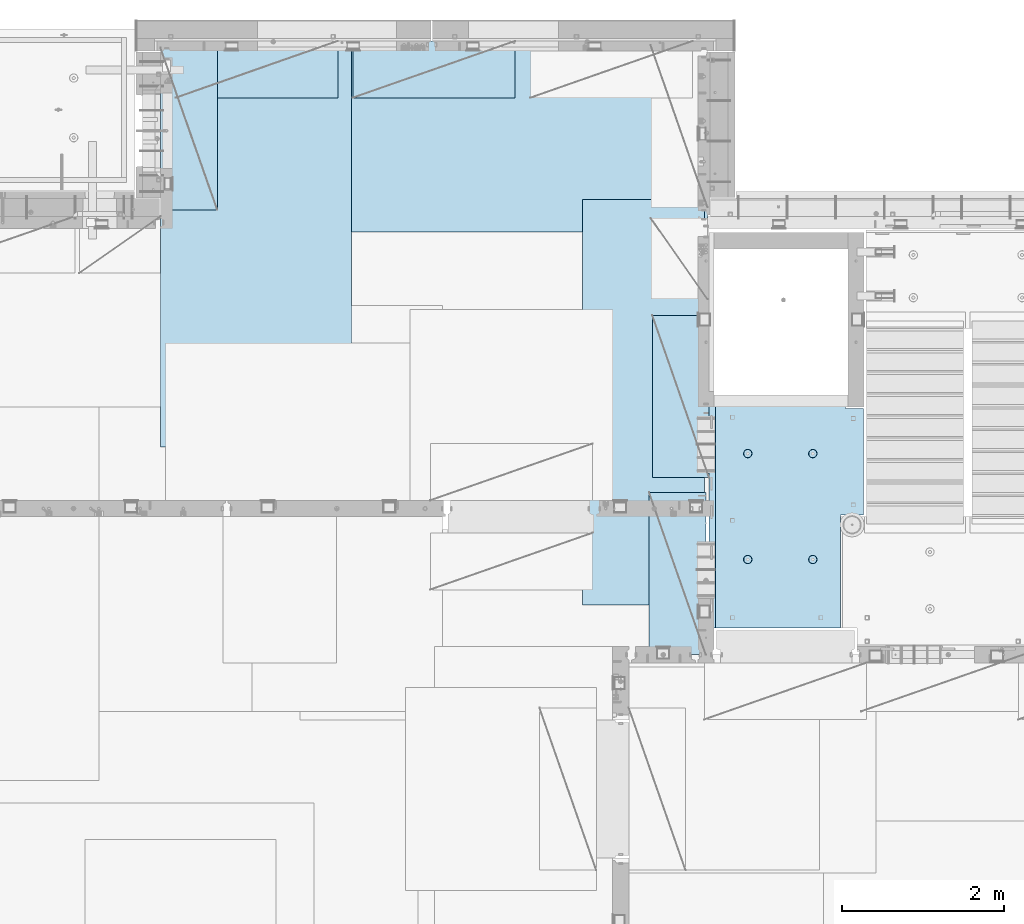
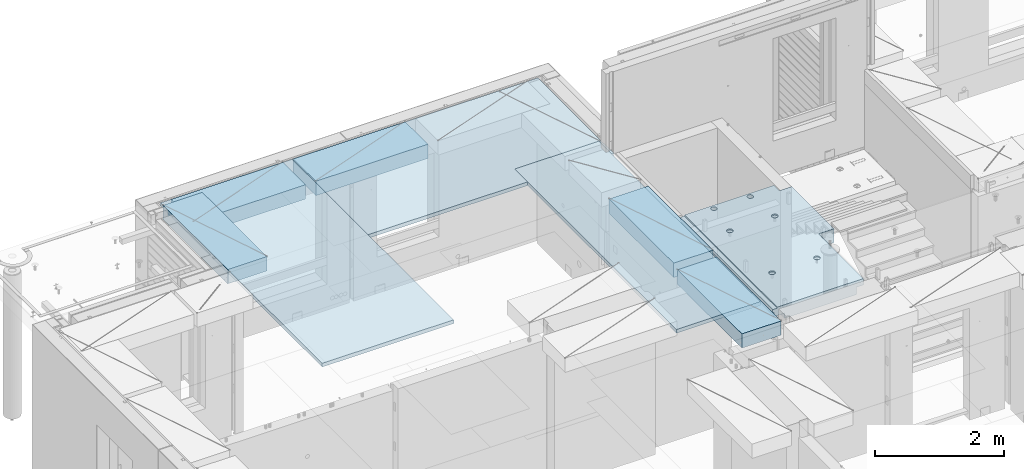
# One storey, part 206 of 349: 8 plates, 1 slab, 9 elements without a shape of their own.
"""IFC2X3 building model written with IfcOpenShell, lengths in millimetres."""

from ifc_helpers import new_model, si_unit, frame, origin_with_axes, place, context, subcontext, project, spatial, faceted_brep, material, type_object, element, aggregate, save


model = new_model("IFC2X3")

# Units and contexts
model_context = context("Model", 3, precision=1e-05, world=origin_with_axes())
body_context = subcontext(model_context, "Body", "Model", "MODEL_VIEW")
ifc_project = project(units=[si_unit("LENGTHUNIT", "METRE", prefix="MILLI"), si_unit("AREAUNIT", "SQUARE_METRE"), si_unit("VOLUMEUNIT", "CUBIC_METRE"), si_unit("MASSUNIT", "GRAM", prefix="KILO"), si_unit("TIMEUNIT", "SECOND"), si_unit("PLANEANGLEUNIT", "RADIAN"), si_unit("SOLIDANGLEUNIT", "STERADIAN"), si_unit("THERMODYNAMICTEMPERATUREUNIT", "DEGREE_CELSIUS"), si_unit("LUMINOUSINTENSITYUNIT", "LUMEN")], contexts=[model_context])

# Site, building, storey
site_placement = place(None, origin_with_axes())
site = spatial("IfcSite", under=ifc_project, at=site_placement, CompositionType="ELEMENT")
building_placement = place(site_placement, origin_with_axes())
building = spatial("IfcBuilding", under=site, at=building_placement, CompositionType="ELEMENT")
storey_placement = place(building_placement, origin_with_axes())
storey = spatial("IfcBuildingStorey", under=building, at=storey_placement, Name="4", CompositionType="ELEMENT", Elevation=0.0)

# Assembly, slab
assembly_1_placement = place(storey_placement, origin_with_axes())
assembly_1 = element("IfcElementAssembly", 1, at=assembly_1_placement, inside=storey, AssemblyPlace="NOTDEFINED", PredefinedType="REINFORCEMENT_UNIT")
ifc_material_1 = material(Name="CONCRETE/C25/30")
slab_type = type_object("IfcSlabType", PredefinedType="NOTDEFINED")
slab_placement = place(assembly_1_placement, frame((19370.0122708302, 15509.9992031236, 93620.0), z_axis=(-0.999999999999509, -9.91000000794397e-07, 0.0), x_axis=(-1.19799915409591e-06, 0.999999999999282, 0.0)))
slab = element("IfcSlab", 2, at=slab_placement, type_object=slab_type, material=ifc_material_1, PredefinedType="FLOOR", context=body_context, shape_type="Brep", body=[
    faceted_brep([(0.00270234311210515, 30.0, 1600.01636881603), (700.003686840937, 30.0, 1600.01632471597), (700.003459213352, 30.0, 1410.0099940095), (0.0034592138545122, 30.0, 1410.0108326095), (700.003459213352, 130.0, 1410.0099940095), (700.003686840937, 50.0008724475629, 1600.01632471597), (700.003710793628, 50.0008724475629, 1620.01159965654), (700.003710793628, 130.0, 1620.01159965654), (0.00238143379829125, 130.0, 1410.01083261132), (2149.99368684227, 30.0, 1600.01623336659), (2149.99345921271, 30.0, 1410.00825692148), (1649.99345921307, 30.0, 1410.00885592148), (1649.99368684195, 30.0, 1600.01626486659), (1390.00354003907, -130.0, -1.24055077321827e-09), (0.0, -130.0, -3.63797880709171e-12), (0.0, -10.0, 0.0), (1390.00503210942, -10.0000000000582, -8.29459168016911e-10), (0.00020267313993827, -10.0000000000582, 119.999691808891), (1390.0049992294, -10.0000000000582, 120.000072670202), (1390.0049992294, 129.999999999942, 120.000072670202), (0.000202673141757259, 130.0, 119.999691808891), (1390.00354003907, 130.0, -1.24055077321827e-09), (1390.00305175782, -130.0, -279.993591308594), (1390.00350516116, 130.0, -19.9999273271205), (1390.00305175782, 130.0, -279.993591308594), (2704.99731446005, 130.0, -279.993808230734), (2704.99731446008, -130.0, -279.993645464809), (2704.99757802008, 130.0, -59.9936454649687), (2704.99757802008, -130.000000000015, -59.9936454649687), (2869.99708830242, -130.0, -59.9938431343799), (2869.99708830242, 130.0, -59.9938431343799), (2869.99538188219, 50.0011350165441, 1600.0161880065), (2869.99536132813, 50.0011350165441, 1620.01123046875), (2149.99371079323, 50.0010478963522, 1620.01135296499), (2149.99368684227, 50.0010478963377, 1600.0162333666), (2869.99536132813, -109.999999999985, 1620.01123046875), (0.00273611420016096, -109.999999999985, 1620.01171875), (0.0026009984267148, -109.999999999985, 1540.01171889739), (2869.99544356416, -109.999999999985, 1540.01180212718), (2869.99536132813, -49.9988649834559, 1620.01123046875), (0.00273611420016096, -49.9992122525582, 1620.01171875), (2869.99538188219, -49.9988649834559, 1600.01618800648), (0.00270234311210515, -49.9992122525582, 1600.01636881602), (2869.99544356416, -129.999999999985, 1540.01180212718), (2869.99536132813, 130.0, 1620.01123046875), (2149.99371079323, 130.0, 1620.01135296499), (2149.99345921271, 130.0, 1410.00825692148), (1649.99345921307, 130.0, 1410.00885592148), (1649.99371079351, 130.0, 1620.01143803163), (1649.99371079351, 50.0009873963572, 1620.01143803163), (1649.99368684195, 50.0009873963427, 1600.0162648666), (0.0026009984267148, -130.0, 1540.01171889739), (858.080152798024, -110.0, 1097.45747495204), (872.018574202059, -110.0, 1104.55943434983), (883.080174557956, -110.0, 1115.62100820216), (890.182167352177, -110.0, 1129.55941258986), (892.62936004754, -110.0, 1145.01025937688), (890.182204372413, -110.0, 1160.46111202734), (883.08024497463, -110.0, 1174.39953343137), (872.018671122296, -110.0, 1185.46113378727), (858.080266734594, -110.0, 1192.56312658148), (842.629419947572, -110.0, 1195.01031927685), (827.178567297122, -110.0, 1192.56316360172), (813.240145893089, -110.0, 1185.46120420394), (802.178545537192, -110.0, 1174.3996303516), (795.076552742968, -110.0, 1160.46122596391), (792.629360047609, -110.0, 1145.01037917688), (795.076515722732, -110.0, 1129.55952652643), (802.178475120518, -110.0, 1115.62110512239), (813.240048972852, -110.0, 1104.5595047665), (827.178453360551, -110.0, 1097.45751197228), (842.629300147573, -110.0, 1095.01031927692), (858.782461559409, -130.0, 1095.29598202818), (842.629297424846, -130.0, 1092.73759200419), (873.354447572716, -130.0, 1102.72075776224), (884.918847944788, -130.0, 1114.28513042604), (892.343658593298, -130.0, 1128.85709864954), (894.902087320264, -130.0, 1145.01025665415), (892.34369729627, -130.0, 1161.16342078871), (884.918921562221, -130.0, 1175.73540680203), (873.354548898418, -130.0, 1187.29980717409), (858.782580674915, -130.0, 1194.72461782261), (842.629422670299, -130.0, 1197.28304654957), (826.476258535738, -130.0, 1194.72465652558), (811.90427252243, -130.0, 1187.29988079152), (800.339872150354, -130.0, 1175.73550812773), (792.915061501848, -130.0, 1161.16353990422), (790.356632774883, -130.0, 1145.01038189961), (792.915022798874, -130.0, 1128.85721776505), (800.339798532925, -130.0, 1114.28523175174), (811.904171196727, -130.0, 1102.72083137967), (826.476139420232, -130.0, 1095.29602073116), (858.08015281103, -110.0, 296.158841760913), (872.018574215066, -110.0, 303.2608011587), (883.080174570961, -110.0, 314.322375011034), (890.182167365187, -110.0, 328.26077939873), (892.629360060546, -110.0, 343.711626185755), (890.182204385423, -110.0, 359.162478836206), (883.080244987636, -110.0, 373.100900240239), (872.018671135302, -110.0, 384.16250059614), (858.0802667476, -110.0, 391.264493390358), (842.62941996058, -110.0, 393.711686085717), (827.178567310128, -110.0, 391.264530410594), (813.240145906095, -110.0, 384.16257101281), (802.178545550198, -110.0, 373.100997160473), (795.076552755974, -110.0, 359.162592772776), (792.629360060615, -110.0, 343.711745985755), (795.076515735738, -110.0, 328.2608933353), (802.178475133525, -110.0, 314.322471931268), (813.240048985859, -110.0, 303.26087157537), (827.178453373557, -110.0, 296.158878781149), (842.629300160579, -110.0, 293.71168608579), (858.782461572417, -130.0, 293.997348837052), (842.629297437852, -130.0, 291.438958813062), (873.354447585723, -130.0, 301.422124571109), (884.918847957797, -130.0, 312.98649723491), (892.343658606304, -130.0, 327.558465458413), (894.90208733327, -130.0, 343.711623463027), (892.343697309276, -130.0, 359.864787597588), (884.918921575227, -130.0, 374.436773610898), (873.354548911424, -130.0, 386.001173982968), (858.782580687921, -130.0, 393.425984631478), (842.629422683307, -130.0, 395.984413358441), (826.476258548744, -130.0, 393.426023334454), (811.904272535436, -130.0, 386.001247600398), (800.339872163362, -130.0, 374.4368749366), (792.915061514856, -130.0, 359.864906713094), (790.356632787889, -130.0, 343.711748708483), (792.915022811882, -130.0, 327.558584573919), (800.339798545931, -130.0, 312.986598560612), (811.904171209735, -130.0, 301.422198188538), (826.47613943324, -130.0, 293.997387540028), (2162.44895919675, -110.0, 1097.45754446905), (2176.38738060079, -110.0, 1104.55950386684), (2187.44898095669, -110.0, 1115.62107771917), (2194.55097375091, -110.0, 1129.55948210687), (2196.99816644627, -110.0, 1145.0103288939), (2194.55101077115, -110.0, 1160.46118154435), (2187.44905137336, -110.0, 1174.39960294838), (2176.38747752102, -110.0, 1185.46120330428), (2162.44907313332, -110.0, 1192.5631960985), (2146.9982263463, -110.0, 1195.01038879386), (2131.54737369585, -110.0, 1192.56323311873), (2117.60895229182, -110.0, 1185.46127372095), (2106.54735193592, -110.0, 1174.39969986862), (2099.4453591417, -110.0, 1160.46129548092), (2096.99816644634, -110.0, 1145.01044869389), (2099.44532212146, -110.0, 1129.55959604344), (2106.54728151925, -110.0, 1115.62117463941), (2117.60885537159, -110.0, 1104.55957428351), (2131.54725975928, -110.0, 1097.45758148929), (2146.9981065463, -110.0, 1095.01038879393), (2163.15126795814, -130.0, 1095.2960515452), (2146.99810382357, -130.0, 1092.73766152121), (2177.72325397145, -130.0, 1102.72082727925), (2189.28765434352, -130.0, 1114.28519994305), (2196.71246499203, -130.0, 1128.85716816655), (2199.27089371899, -130.0, 1145.01032617117), (2196.71250369501, -130.0, 1161.16349030573), (2189.28772796095, -130.0, 1175.73547631904), (2177.72335529715, -130.0, 1187.29987669111), (2163.15138707365, -130.0, 1194.72468733962), (2146.99822906903, -130.0, 1197.28311606658), (2130.84506493447, -130.0, 1194.72472604259), (2116.27307892116, -130.0, 1187.29995030854), (2104.70867854909, -130.0, 1175.73557764474), (2097.28386790058, -130.0, 1161.16360942123), (2094.72543917361, -130.0, 1145.01045141662), (2097.2838291976, -130.0, 1128.85728728206), (2104.70860493166, -130.0, 1114.28530126875), (2116.27297759546, -130.0, 1102.72090089668), (2130.84494581896, -130.0, 1095.29609024817), (2162.44895913772, -110.0, 296.158911320326), (2176.38738054176, -110.0, 303.260870718113), (2187.44898089765, -110.0, 314.322444570447), (2194.55097369188, -110.0, 328.260848958147), (2196.99816638724, -110.0, 343.711695745169), (2194.55101071211, -110.0, 359.162548395623), (2187.44905131433, -110.0, 373.100969799652), (2176.38747746199, -110.0, 384.162570155553), (2162.44907307429, -110.0, 391.264562949771), (2146.99822628727, -110.0, 393.711755645134), (2131.54737363682, -110.0, 391.264599970007), (2117.60895223279, -110.0, 384.162640572227), (2106.54735187689, -110.0, 373.10106671989), (2099.44535908267, -110.0, 359.162662332194), (2096.99816638731, -110.0, 343.711815545168), (2099.44532206243, -110.0, 328.260962894718), (2106.54728146021, -110.0, 314.322541490685), (2117.60885531255, -110.0, 303.260941134788), (2131.54725970025, -110.0, 296.158948340562), (2146.99810648727, -110.0, 293.711755645207), (2163.15126789911, -130.0, 293.997418396466), (2146.99810376454, -130.0, 291.439028372479), (2177.72325391241, -130.0, 301.422194130522), (2189.28765428449, -130.0, 312.986566794323), (2196.712464933, -130.0, 327.558535017826), (2199.27089365996, -130.0, 343.711693022444), (2196.71250363597, -130.0, 359.864857157001), (2189.28772790192, -130.0, 374.436843170311), (2177.72335523811, -130.0, 386.001243542381), (2163.15138701461, -130.0, 393.426054190892), (2146.99822901, -130.0, 395.984482917858), (2130.84506487544, -130.0, 393.426092893867), (2116.27307886213, -130.0, 386.001317159811), (2104.70867849006, -130.0, 374.436944496014), (2097.28386784155, -130.0, 359.864976272507), (2094.72543911458, -130.0, 343.711818267897), (2097.28382913857, -130.0, 327.558654133332), (2104.70860487263, -130.0, 312.986668120026), (2116.27297753642, -130.0, 301.422267747952), (2130.84494575993, -130.0, 293.997457099442), (2805.44844412025, -130.0, 362.453408379821), (2805.44844412025, 130.0, 362.453408379821), (2789.9975914698, 130.0, 360.006252704694), (2789.9975914698, -130.0, 360.006252704694), (2819.38686552428, -130.0, 369.555367777604), (2819.38686552428, 130.0, 369.555367777604), (2830.44846588018, -130.0, 380.616941629942), (2830.44846588018, 130.0, 380.616941629942), (2837.5504586744, -130.0, 394.555346017638), (2837.5504586744, 130.0, 394.555346017638), (2839.99765136976, -130.0, 410.006192804663), (2839.99765136976, 130.0, 410.006192804663), (2837.55049569464, -130.0, 425.457045455114), (2837.55049569464, 130.0, 425.457045455114), (2830.44853629686, -130.0, 439.395466859147), (2830.44853629686, 130.0, 439.395466859147), (2819.38696244451, -130.0, 450.457067215044), (2819.38696244451, 130.0, 450.457067215044), (2805.44855805682, -130.0, 457.559060009266), (2805.44855805682, 130.0, 457.559060009266), (2789.9977112698, -130.0, 460.006252704625), (2789.9977112698, 130.0, 460.006252704625), (2774.54685861935, -130.0, 457.559097029502), (2774.54685861935, 130.0, 457.559097029502), (2760.60843721531, -130.0, 450.457137631718), (2760.60843721531, 130.0, 450.457137631718), (2749.54683685942, -130.0, 439.395563779381), (2749.54683685942, 130.0, 439.395563779381), (2742.44484406519, -130.0, 425.457159391684), (2742.44484406519, 130.0, 425.457159391684), (2739.99765136983, -130.0, 410.006312604663), (2739.99765136983, 130.0, 410.006312604663), (2742.44480704495, -130.0, 394.555459954208), (2742.44480704495, 130.0, 394.555459954208), (2749.54676644274, -130.0, 380.617038550175), (2749.54676644274, 130.0, 380.617038550175), (2760.60834029508, -130.0, 369.555438194278), (2760.60834029508, 130.0, 369.555438194278), (2774.54674468278, -130.0, 362.453445400057), (2774.54674468278, 130.0, 362.453445400057), (2760.60911899507, -130.0, 1019.55543819397), (2749.54754514274, -130.0, 1030.61703854987), (2742.44558574495, -130.0, 1044.5554599539), (2739.99843006983, -130.0, 1060.00631260435), (2742.44562276519, -130.0, 1075.45715939137), (2749.54761555942, -130.0, 1089.39556377907), (2760.60921591531, -130.0, 1100.45713763141), (2774.54763731935, -130.0, 1107.55909702919), (2789.9984899698, -130.0, 1110.00625270432), (2805.44933675682, -130.0, 1107.55906000896), (2819.38774114452, -130.0, 1100.45706721473), (2830.44931499685, -130.0, 1089.39546685884), (2837.55127439463, -130.0, 1075.4570454548), (2839.99843006976, -130.0, 1060.00619280435), (2837.5512373744, -130.0, 1044.55534601733), (2830.44924458018, -130.0, 1030.61694162963), (2819.38764422428, -130.0, 1019.55536777729), (2805.44922282025, -130.0, 1012.45340837951), (2789.9983701698, -130.0, 1010.00625270438), (2774.54752338277, -130.0, 1012.45344539975), (2819.38764422428, 130.0, 1019.55536777729), (2805.44922282025, 130.0, 1012.45340837951), (2830.44924458018, 130.0, 1030.61694162963), (2837.5512373744, 130.0, 1044.55534601733), (2839.99843006976, 130.0, 1060.00619280435), (2837.55127439463, 130.0, 1075.4570454548), (2830.44931499685, 130.0, 1089.39546685884), (2819.38774114452, 130.0, 1100.45706721473), (2805.44933675682, 130.0, 1107.55906000896), (2789.9984899698, 130.0, 1110.00625270432), (2774.54763731935, 130.0, 1107.55909702919), (2760.60921591531, 130.0, 1100.45713763141), (2749.54761555942, 130.0, 1089.39556377907), (2742.44562276519, 130.0, 1075.45715939137), (2739.99843006983, 130.0, 1060.00631260435), (2742.44558574495, 130.0, 1044.5554599539), (2749.54754514274, 130.0, 1030.61703854987), (2760.60911899507, 130.0, 1019.55543819397), (2774.54752338277, 130.0, 1012.45344539975), (2789.9983701698, 130.0, 1010.00625270438)], [[[0, 1, 2, 3]], [[4, 2, 1, 5, 6, 7]], [[8, 3, 2, 4]], [[9, 10, 11, 12]], [[13, 14, 15, 16]], [[15, 17, 18, 16]], [[19, 18, 17, 20]], [[16, 18, 19, 21]], [[22, 13, 16, 21, 23, 24]], [[22, 24, 25, 26]], [[26, 25, 27, 28]], [[29, 28, 27, 30]], [[31, 32, 33, 34]], [[35, 36, 37, 38]], [[36, 35, 39, 40]], [[41, 42, 40, 39]], [[35, 38, 43, 29, 30, 44, 32, 31, 41, 39]], [[32, 44, 45, 33]], [[46, 10, 9, 34, 33, 45]], [[47, 11, 10, 46]], [[48, 49, 50, 12, 11, 47]], [[49, 48, 7, 6]], [[50, 49, 6, 5]], [[42, 41, 31, 34, 9, 12, 50, 5, 1, 0]], [[20, 17, 15, 14, 51, 37, 36, 40, 42, 0, 3, 8]], [[43, 38, 37, 51]], [[52, 53, 54, 55, 56, 57, 58, 59, 60, 61, 62, 63, 64, 65, 66, 67, 68, 69, 70, 71]], [[72, 52, 71, 73]], [[74, 53, 52, 72]], [[75, 54, 53, 74]], [[76, 55, 54, 75]], [[77, 56, 55, 76]], [[78, 57, 56, 77]], [[79, 58, 57, 78]], [[80, 59, 58, 79]], [[81, 60, 59, 80]], [[82, 61, 60, 81]], [[83, 62, 61, 82]], [[84, 63, 62, 83]], [[85, 64, 63, 84]], [[86, 65, 64, 85]], [[87, 66, 65, 86]], [[88, 67, 66, 87]], [[89, 68, 67, 88]], [[90, 69, 68, 89]], [[91, 70, 69, 90]], [[73, 71, 70, 91]], [[92, 93, 94, 95, 96, 97, 98, 99, 100, 101, 102, 103, 104, 105, 106, 107, 108, 109, 110, 111]], [[112, 92, 111, 113]], [[114, 93, 92, 112]], [[115, 94, 93, 114]], [[116, 95, 94, 115]], [[117, 96, 95, 116]], [[118, 97, 96, 117]], [[119, 98, 97, 118]], [[120, 99, 98, 119]], [[121, 100, 99, 120]], [[122, 101, 100, 121]], [[123, 102, 101, 122]], [[124, 103, 102, 123]], [[125, 104, 103, 124]], [[126, 105, 104, 125]], [[127, 106, 105, 126]], [[128, 107, 106, 127]], [[129, 108, 107, 128]], [[130, 109, 108, 129]], [[131, 110, 109, 130]], [[113, 111, 110, 131]], [[132, 133, 134, 135, 136, 137, 138, 139, 140, 141, 142, 143, 144, 145, 146, 147, 148, 149, 150, 151]], [[152, 132, 151, 153]], [[154, 133, 132, 152]], [[155, 134, 133, 154]], [[156, 135, 134, 155]], [[157, 136, 135, 156]], [[158, 137, 136, 157]], [[159, 138, 137, 158]], [[160, 139, 138, 159]], [[161, 140, 139, 160]], [[162, 141, 140, 161]], [[163, 142, 141, 162]], [[164, 143, 142, 163]], [[165, 144, 143, 164]], [[166, 145, 144, 165]], [[167, 146, 145, 166]], [[168, 147, 146, 167]], [[169, 148, 147, 168]], [[170, 149, 148, 169]], [[171, 150, 149, 170]], [[153, 151, 150, 171]], [[172, 173, 174, 175, 176, 177, 178, 179, 180, 181, 182, 183, 184, 185, 186, 187, 188, 189, 190, 191]], [[192, 172, 191, 193]], [[194, 173, 172, 192]], [[195, 174, 173, 194]], [[196, 175, 174, 195]], [[197, 176, 175, 196]], [[198, 177, 176, 197]], [[199, 178, 177, 198]], [[200, 179, 178, 199]], [[201, 180, 179, 200]], [[202, 181, 180, 201]], [[203, 182, 181, 202]], [[204, 183, 182, 203]], [[205, 184, 183, 204]], [[206, 185, 184, 205]], [[207, 186, 185, 206]], [[208, 187, 186, 207]], [[209, 188, 187, 208]], [[210, 189, 188, 209]], [[211, 190, 189, 210]], [[193, 191, 190, 211]], [[212, 213, 214, 215]], [[216, 217, 213, 212]], [[218, 219, 217, 216]], [[220, 221, 219, 218]], [[222, 223, 221, 220]], [[224, 225, 223, 222]], [[226, 227, 225, 224]], [[228, 229, 227, 226]], [[230, 231, 229, 228]], [[232, 233, 231, 230]], [[234, 235, 233, 232]], [[236, 237, 235, 234]], [[238, 239, 237, 236]], [[240, 241, 239, 238]], [[242, 243, 241, 240]], [[244, 245, 243, 242]], [[246, 247, 245, 244]], [[248, 249, 247, 246]], [[250, 251, 249, 248]], [[215, 214, 251, 250]], [[14, 13, 22, 26, 28, 29, 43, 51], [252, 253, 254, 255, 256, 257, 258, 259, 260, 261, 262, 263, 264, 265, 266, 267, 268, 269, 270, 271], [248, 246, 244, 242, 240, 238, 236, 234, 232, 230, 228, 226, 224, 222, 220, 218, 216, 212, 215, 250], [210, 209, 208, 207, 206, 205, 204, 203, 202, 201, 200, 199, 198, 197, 196, 195, 194, 192, 193, 211], [170, 169, 168, 167, 166, 165, 164, 163, 162, 161, 160, 159, 158, 157, 156, 155, 154, 152, 153, 171], [130, 129, 128, 127, 126, 125, 124, 123, 122, 121, 120, 119, 118, 117, 116, 115, 114, 112, 113, 131], [90, 89, 88, 87, 86, 85, 84, 83, 82, 81, 80, 79, 78, 77, 76, 75, 74, 72, 73, 91]], [[268, 272, 273, 269]], [[267, 274, 272, 268]], [[266, 275, 274, 267]], [[265, 276, 275, 266]], [[264, 277, 276, 265]], [[263, 278, 277, 264]], [[262, 279, 278, 263]], [[261, 280, 279, 262]], [[260, 281, 280, 261]], [[259, 282, 281, 260]], [[258, 283, 282, 259]], [[257, 284, 283, 258]], [[256, 285, 284, 257]], [[255, 286, 285, 256]], [[254, 287, 286, 255]], [[253, 288, 287, 254]], [[252, 289, 288, 253]], [[271, 290, 289, 252]], [[270, 291, 290, 271]], [[269, 273, 291, 270]], [[48, 47, 46, 45, 44, 30, 27, 25, 24, 23, 21, 19, 20, 8, 4, 7], [272, 274, 275, 276, 277, 278, 279, 280, 281, 282, 283, 284, 285, 286, 287, 288, 289, 290, 291, 273], [217, 219, 221, 223, 225, 227, 229, 231, 233, 235, 237, 239, 241, 243, 245, 247, 249, 251, 214, 213]]]),
])
aggregate(assembly_1, [slab])

# Assembly, plate
assembly_2_placement = place(storey_placement, origin_with_axes())
assembly_2 = element("IfcElementAssembly", 3, at=assembly_2_placement, inside=storey, Name="Steel Assembly", AssemblyPlace="NOTDEFINED", PredefinedType="NOTDEFINED")
ifc_material_2 = material()
plate_type_1 = type_object("IfcPlateType", PredefinedType="NOTDEFINED")
plate_1_placement = place(assembly_2_placement, frame((12729.9998779297, 22740.0009765625, 93695.1), z_axis=(1.0, 0.0, 0.0), x_axis=(0.0, -1.0, 0.0)))
plate_1 = element("IfcPlate", 4, at=plate_1_placement, type_object=plate_type_1, material=ifc_material_2, context=body_context, shape_type="Brep", body=[
    faceted_brep([(0.0, -35.0, 0.0), (0.0, -35.0, 5000.0), (0.0, 35.0, 5000.0), (0.0, 35.0, 0.0), (2349.99951171875, -35.0, 5000.0), (2349.99951171875, 35.0, 5000.0), (2350.0, -35.0, 0.0), (2350.0, 35.0, 0.0)], [[[0, 1, 2, 3]], [[1, 4, 5, 2]], [[4, 6, 7, 5]], [[6, 0, 3, 7]], [[5, 7, 3, 2]], [[6, 4, 1, 0]]]),
])
aggregate(assembly_2, [plate_1])

assembly_3_placement = place(storey_placement, origin_with_axes())
assembly_3 = element("IfcElementAssembly", 5, at=assembly_3_placement, inside=storey, Name="Steel Assembly", AssemblyPlace="NOTDEFINED", PredefinedType="NOTDEFINED")
plate_2_placement = place(assembly_3_placement, frame((13340.0, 22740.0, 93695.1), z_axis=(0.0, -1.0, 0.0), x_axis=(-1.0, 3.00000001838171e-08, 0.0)))
plate_2 = element("IfcPlate", 6, at=plate_2_placement, type_object=plate_type_1, material=ifc_material_2, context=body_context, shape_type="Brep", body=[
    faceted_brep([(0.0, -35.0, 0.0), (0.0, -35.0, 5000.0), (0.0, 35.0, 5000.0), (0.0, 35.0, 0.0), (2349.99951171875, -35.0, 5000.0), (2349.99951171875, 35.0, 5000.0), (2350.0, -35.0, 0.0), (2350.0, 35.0, 0.0)], [[[0, 1, 2, 3]], [[1, 4, 5, 2]], [[4, 6, 7, 5]], [[6, 0, 3, 7]], [[5, 7, 3, 2]], [[6, 4, 1, 0]]]),
])
aggregate(assembly_3, [plate_2])

assembly_4_placement = place(storey_placement, origin_with_axes())
assembly_4 = element("IfcElementAssembly", 7, at=assembly_4_placement, inside=storey, Name="Steel Assembly", AssemblyPlace="NOTDEFINED", PredefinedType="NOTDEFINED")
plate_type_2 = type_object("IfcPlateType", PredefinedType="NOTDEFINED")
plate_3_placement = place(assembly_4_placement, frame((17690.0000122641, 20790.0, 93695.1000003815), z_axis=(0.0, -1.0, 0.0), x_axis=(-1.0, 3.00000001838171e-08, 0.0)))
plate_3 = element("IfcPlate", 8, at=plate_3_placement, type_object=plate_type_2, material=ifc_material_2, context=body_context, shape_type="Brep", body=[
    faceted_brep([(0.0, -35.0, 0.0), (0.0, -35.0, 5000.0), (0.0, 35.0, 5000.0), (0.0, 35.0, 0.0), (1499.99951171875, -35.0, 5000.0), (1499.99951171875, 35.0, 5000.0), (1500.0, -35.0, 0.0), (1500.0, 35.0, 0.0)], [[[0, 1, 2, 3]], [[1, 4, 5, 2]], [[4, 6, 7, 5]], [[6, 0, 3, 7]], [[5, 7, 3, 2]], [[6, 4, 1, 0]]]),
])
aggregate(assembly_4, [plate_3])

assembly_5_placement = place(storey_placement, origin_with_axes())
assembly_5 = element("IfcElementAssembly", 9, at=assembly_5_placement, inside=storey, Name="Steel Assembly", AssemblyPlace="NOTDEFINED", PredefinedType="NOTDEFINED")
plate_type_3 = type_object("IfcPlateType", PredefinedType="NOTDEFINED")
plate_4_placement = place(assembly_5_placement, frame((17750.0001220703, 17360.0, 93595.3), z_axis=(-1.0, 3.00000001838171e-08, 0.0), x_axis=(0.0, 1.0, 0.0)))
plate_4 = element("IfcPlate", 10, at=plate_4_placement, type_object=plate_type_3, material=ifc_material_2, Name="RE1", context=body_context, shape_type="Brep", body=[
    faceted_brep([(1.81898940354586e-12, -135.0, 1.81898940354586e-12), (0.0, -135.0, 699.999999999996), (0.0, 135.0, 699.999999999996), (1.81898940354586e-12, 135.0, 1.81898940354586e-12), (1999.99951171875, -135.0, 699.999999999993), (1999.99951171875, 135.0, 699.999999999993), (2000.0, -135.0, -3.63797880709171e-12), (2000.0, 135.0, -3.63797880709171e-12)], [[[0, 1, 2, 3]], [[1, 4, 5, 2]], [[4, 6, 7, 5]], [[6, 0, 3, 7]], [[5, 7, 3, 2]], [[6, 4, 1, 0]]]),
])
aggregate(assembly_5, [plate_4])

assembly_6_placement = place(storey_placement, origin_with_axes())
assembly_6 = element("IfcElementAssembly", 11, at=assembly_6_placement, inside=storey, Name="Steel Assembly", AssemblyPlace="NOTDEFINED", PredefinedType="NOTDEFINED")
plate_5_placement = place(assembly_6_placement, frame((17710.0001220703, 15180.0, 93595.3), z_axis=(-1.0, 3.00000001838171e-08, 0.0), x_axis=(0.0, 1.0, 0.0)))
plate_5 = element("IfcPlate", 12, at=plate_5_placement, type_object=plate_type_3, material=ifc_material_2, Name="RE1", context=body_context, shape_type="Brep", body=[
    faceted_brep([(1.81898940354586e-12, -135.0, 1.81898940354586e-12), (0.0, -135.0, 699.999999999996), (0.0, 135.0, 699.999999999996), (1.81898940354586e-12, 135.0, 1.81898940354586e-12), (1999.99951171875, -135.0, 699.999999999993), (1999.99951171875, 135.0, 699.999999999993), (2000.0, -135.0, -3.63797880709171e-12), (2000.0, 135.0, -3.63797880709171e-12)], [[[0, 1, 2, 3]], [[1, 4, 5, 2]], [[4, 6, 7, 5]], [[6, 0, 3, 7]], [[5, 7, 3, 2]], [[6, 4, 1, 0]]]),
])
aggregate(assembly_6, [plate_5])

assembly_7_placement = place(storey_placement, origin_with_axes())
assembly_7 = element("IfcElementAssembly", 13, at=assembly_7_placement, inside=storey, Name="Steel Assembly", AssemblyPlace="NOTDEFINED", PredefinedType="NOTDEFINED")
plate_6_placement = place(assembly_7_placement, frame((13175.0, 22740.0001220703, 93595.3), z_axis=(0.0, -1.0, 0.0), x_axis=(-1.0, 3.00000001838171e-08, 0.0)))
plate_6 = element("IfcPlate", 14, at=plate_6_placement, type_object=plate_type_3, material=ifc_material_2, Name="RE1", context=body_context, shape_type="Brep", body=[
    faceted_brep([(1.81898940354586e-12, -135.0, 1.81898940354586e-12), (0.0, -135.0, 699.999999999996), (0.0, 135.0, 699.999999999996), (1.81898940354586e-12, 135.0, 1.81898940354586e-12), (1999.99951171875, -135.0, 699.999999999993), (1999.99951171875, 135.0, 699.999999999993), (2000.0, -135.0, -3.63797880709171e-12), (2000.0, 135.0, -3.63797880709171e-12)], [[[0, 1, 2, 3]], [[1, 4, 5, 2]], [[4, 6, 7, 5]], [[6, 0, 3, 7]], [[5, 7, 3, 2]], [[6, 4, 1, 0]]]),
])
aggregate(assembly_7, [plate_6])

assembly_8_placement = place(storey_placement, origin_with_axes())
assembly_8 = element("IfcElementAssembly", 15, at=assembly_8_placement, inside=storey, Name="Steel Assembly", AssemblyPlace="NOTDEFINED", PredefinedType="NOTDEFINED")
plate_7_placement = place(assembly_8_placement, frame((15360.0, 22740.0001220703, 93595.3), z_axis=(0.0, -1.0, 0.0), x_axis=(-1.0, 3.00000001838171e-08, 0.0)))
plate_7 = element("IfcPlate", 16, at=plate_7_placement, type_object=plate_type_3, material=ifc_material_2, Name="RE1", context=body_context, shape_type="Brep", body=[
    faceted_brep([(1.81898940354586e-12, -135.0, 1.81898940354586e-12), (0.0, -135.0, 699.999999999996), (0.0, 135.0, 699.999999999996), (1.81898940354586e-12, 135.0, 1.81898940354586e-12), (1999.99951171875, -135.0, 699.999999999993), (1999.99951171875, 135.0, 699.999999999993), (2000.0, -135.0, -3.63797880709171e-12), (2000.0, 135.0, -3.63797880709171e-12)], [[[0, 1, 2, 3]], [[1, 4, 5, 2]], [[4, 6, 7, 5]], [[6, 0, 3, 7]], [[5, 7, 3, 2]], [[6, 4, 1, 0]]]),
])
aggregate(assembly_8, [plate_7])

assembly_9_placement = place(storey_placement, origin_with_axes())
assembly_9 = element("IfcElementAssembly", 17, at=assembly_9_placement, inside=storey, Name="Steel Assembly", AssemblyPlace="NOTDEFINED", PredefinedType="NOTDEFINED")
plate_8_placement = place(assembly_9_placement, frame((10989.9998779297, 22660.0, 93595.3), z_axis=(1.0, 0.0, 0.0), x_axis=(0.0, -1.0, 0.0)))
plate_8 = element("IfcPlate", 18, at=plate_8_placement, type_object=plate_type_3, material=ifc_material_2, Name="RE1", context=body_context, shape_type="Brep", body=[
    faceted_brep([(1.81898940354586e-12, -135.0, 1.81898940354586e-12), (0.0, -135.0, 699.999999999996), (0.0, 135.0, 699.999999999996), (1.81898940354586e-12, 135.0, 1.81898940354586e-12), (1999.99951171875, -135.0, 699.999999999993), (1999.99951171875, 135.0, 699.999999999993), (2000.0, -135.0, -3.63797880709171e-12), (2000.0, 135.0, -3.63797880709171e-12)], [[[0, 1, 2, 3]], [[1, 4, 5, 2]], [[4, 6, 7, 5]], [[6, 0, 3, 7]], [[5, 7, 3, 2]], [[6, 4, 1, 0]]]),
])
aggregate(assembly_9, [plate_8])

save(model, "model.ifc")
